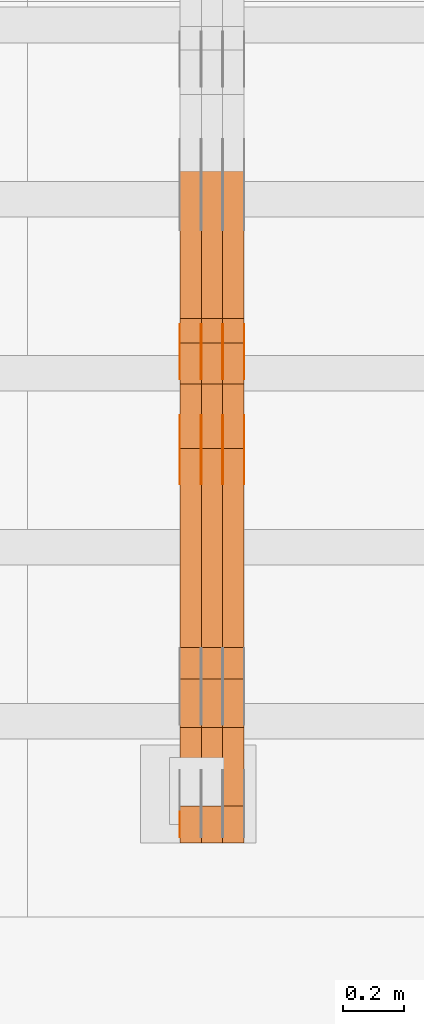
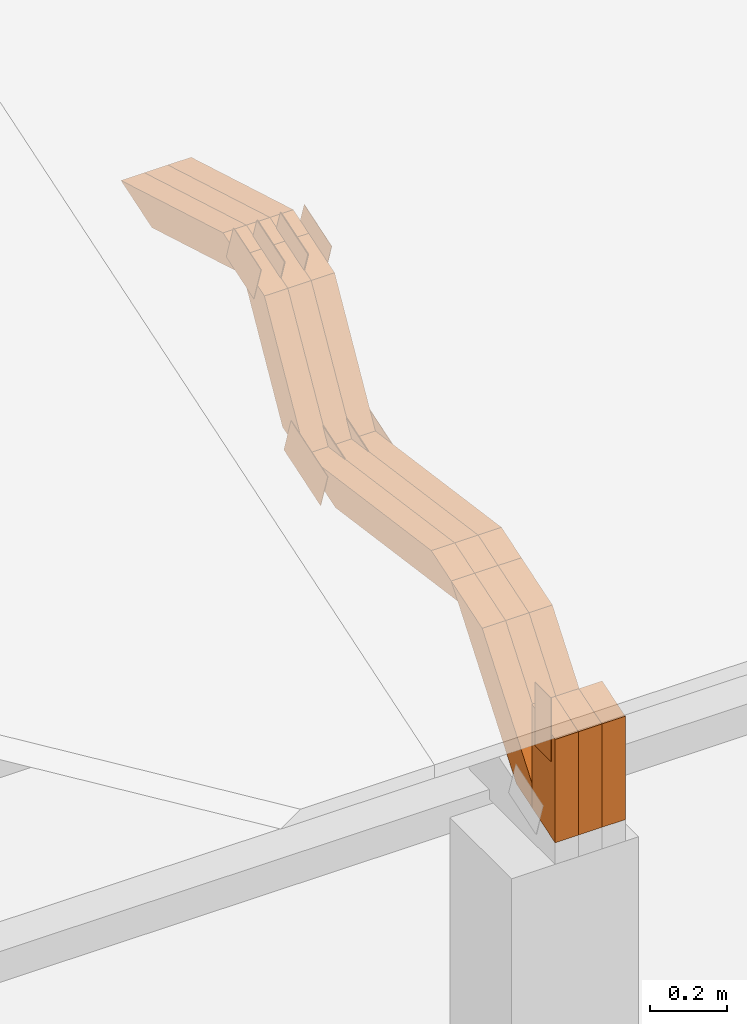
# One storey, part 59 of 385: 28 proxies.
"""IFC2X3 building model written with IfcOpenShell, lengths in millimetres."""

from ifc_helpers import new_model, entity, si_unit, converted_unit, derived_unit, direction, frame, frame_2d, origin, place, context, subcontext, project, spatial, polyline, rectangle, outline, extrude, source, transform, mapped, material, type_object, type_shapes, element, save


model = new_model("IFC2X3")

# Units and contexts
model_context = context("Model", 3, precision=0.01, world=origin(), true_north=direction((6.12303176911189e-17, 1.0)))
body_context = subcontext(model_context, "Body", "Model", "MODEL_VIEW")
ifc_project = project(units=[si_unit("LENGTHUNIT", "METRE", prefix="MILLI"), si_unit("AREAUNIT", "SQUARE_METRE"), si_unit("VOLUMEUNIT", "CUBIC_METRE"), converted_unit("PLANEANGLEUNIT", "DEGREE", entity("IfcRatioMeasure", 0.0174532925199433), si_unit("PLANEANGLEUNIT", "RADIAN"), dimensions=[0, 0, 0, 0, 0, 0, 0]), si_unit("MASSUNIT", "GRAM", prefix="KILO"), derived_unit("MASSDENSITYUNIT", [(si_unit("MASSUNIT", "GRAM", prefix="KILO"), 1), (si_unit("LENGTHUNIT", "METRE"), -3)]), si_unit("TIMEUNIT", "SECOND"), si_unit("FREQUENCYUNIT", "HERTZ"), si_unit("THERMODYNAMICTEMPERATUREUNIT", "DEGREE_CELSIUS"), derived_unit("THERMALTRANSMITTANCEUNIT", [(si_unit("MASSUNIT", "GRAM", prefix="KILO"), 1), (si_unit("THERMODYNAMICTEMPERATUREUNIT", "KELVIN"), -1), (si_unit("TIMEUNIT", "SECOND"), -3)]), derived_unit("VOLUMETRICFLOWRATEUNIT", [(si_unit("LENGTHUNIT", "METRE"), 3), (si_unit("TIMEUNIT", "SECOND"), -1)]), si_unit("ELECTRICCURRENTUNIT", "AMPERE"), si_unit("ELECTRICVOLTAGEUNIT", "VOLT"), si_unit("POWERUNIT", "WATT"), si_unit("FORCEUNIT", "NEWTON", prefix="KILO"), si_unit("ILLUMINANCEUNIT", "LUX"), si_unit("LUMINOUSFLUXUNIT", "LUMEN"), si_unit("LUMINOUSINTENSITYUNIT", "CANDELA"), derived_unit("USERDEFINED", [(si_unit("MASSUNIT", "GRAM", prefix="KILO"), -1), (si_unit("LENGTHUNIT", "METRE"), -2), (si_unit("TIMEUNIT", "SECOND"), 3), (si_unit("LUMINOUSFLUXUNIT", "LUMEN"), 1)]), derived_unit("LINEARVELOCITYUNIT", [(si_unit("LENGTHUNIT", "METRE"), 1), (si_unit("TIMEUNIT", "SECOND"), -1)]), si_unit("PRESSUREUNIT", "PASCAL"), derived_unit("USERDEFINED", [(si_unit("LENGTHUNIT", "METRE"), -2), (si_unit("MASSUNIT", "GRAM", prefix="KILO"), 1), (si_unit("TIMEUNIT", "SECOND"), -2)])], contexts=[model_context])

# Site, building, storey
site_placement = place(None, origin())
site = spatial("IfcSite", under=ifc_project, at=site_placement, CompositionType="ELEMENT")
building_placement = place(site_placement, origin())
building = spatial("IfcBuilding", under=site, at=building_placement, CompositionType="ELEMENT")
storey_placement = place(building_placement, origin())
storey = spatial("IfcBuildingStorey", under=building, at=storey_placement, Name="Default", CompositionType="ELEMENT", Elevation=0.0)

# Proxies
ifc_material_1 = material(Name="IfcSurfaceStyle #201958")
building_element_proxy_type_1 = type_object("IfcBuildingElementProxyType", PredefinedType="NOTDEFINED", material=ifc_material_1)
shared_shape_1 = source(origin(), body_context, "Body", "SweptSolid", [
    extrude(outline(polyline([(-99.9998204243802, -60.000067376167), (99.9998338462265, -60.000067376167), (99.9998204243802, 60.000067376167), (-99.9998338462265, 60.000067376167), (-99.9998204243802, -60.000067376167)])), frame((100.000602015329, 60.0001864986889, 0.0), z_axis=(0.0, 0.0, 1.0), x_axis=(-1.0, 0.0, 0.0)), (0.0, 0.0, 1.0), 1.3),
])
type_shapes(building_element_proxy_type_1, [shared_shape_1])
proxy_1_placement = place(building_placement, frame((15386.3, 4114.85465165112, 513.097031388771), z_axis=(-1.0, 0.0, 0.0), x_axis=(0.0, 0.951056516295124, 0.309016994375039)))
element("IfcBuildingElementProxy", 1, at=proxy_1_placement, inside=storey, type_object=building_element_proxy_type_1, material=ifc_material_1, context=body_context, shape_type="MappedRepresentation", body=[
    mapped(shared_shape_1, transform((0.0, 0.0, 0.0), scale=1.0)),
])
ifc_material_2 = material(Name="IfcSurfaceStyle #201901")
building_element_proxy_type_2 = type_object("IfcBuildingElementProxyType", PredefinedType="NOTDEFINED", material=ifc_material_2)
shared_shape_2 = source(origin(), body_context, "Body", "SweptSolid", [
    extrude(outline(polyline([(-99.9998204243802, -60.000067376167), (99.9998338462265, -60.000067376167), (99.9998204243802, 60.000067376167), (-99.9998338462265, 60.000067376167), (-99.9998204243802, -60.000067376167)])), frame((100.000602015329, 60.0001864986889, 0.0), z_axis=(0.0, 0.0, 1.0), x_axis=(-1.0, 0.0, 0.0)), (0.0, 0.0, 1.0), 1.3),
])
type_shapes(building_element_proxy_type_2, [shared_shape_2])
proxy_2_placement = place(building_placement, frame((15315.0, 4114.85465165112, 513.097031388771), z_axis=(-1.0, 0.0, 0.0), x_axis=(0.0, 0.951056516295124, 0.309016994375039)))
element("IfcBuildingElementProxy", 2, at=proxy_2_placement, inside=storey, type_object=building_element_proxy_type_2, material=ifc_material_2, context=body_context, shape_type="MappedRepresentation", body=[
    mapped(shared_shape_2, transform((0.0, 0.0, 0.0), scale=1.0)),
])
ifc_material_3 = material(Name="IfcSurfaceStyle #201844")
building_element_proxy_type_3 = type_object("IfcBuildingElementProxyType", PredefinedType="NOTDEFINED", material=ifc_material_3)
shared_shape_3 = source(origin(), body_context, "Body", "SweptSolid", [
    extrude(outline(polyline([(-99.9998204243802, -60.000067376167), (99.9998338462265, -60.000067376167), (99.9998204243802, 60.000067376167), (-99.9998338462265, 60.000067376167), (-99.9998204243802, -60.000067376167)])), frame((100.000602015329, 60.0001864986889, 0.0), z_axis=(0.0, 0.0, 1.0), x_axis=(-1.0, 0.0, 0.0)), (0.0, 0.0, 1.0), 1.3),
])
type_shapes(building_element_proxy_type_3, [shared_shape_3])
proxy_3_placement = place(building_placement, frame((15316.3, 4114.85465165112, 513.097031388771), z_axis=(-1.0, 0.0, 0.0), x_axis=(0.0, 0.951056516295124, 0.309016994375039)))
element("IfcBuildingElementProxy", 3, at=proxy_3_placement, inside=storey, type_object=building_element_proxy_type_3, material=ifc_material_3, context=body_context, shape_type="MappedRepresentation", body=[
    mapped(shared_shape_3, transform((0.0, 0.0, 0.0), scale=1.0)),
])
ifc_material_4 = material(Name="IfcSurfaceStyle #201787")
building_element_proxy_type_4 = type_object("IfcBuildingElementProxyType", PredefinedType="NOTDEFINED", material=ifc_material_4)
shared_shape_4 = source(origin(), body_context, "Body", "SweptSolid", [
    extrude(outline(polyline([(-99.9998204243802, -60.000067376167), (99.9998338462265, -60.000067376167), (99.9998204243802, 60.000067376167), (-99.9998338462265, 60.000067376167), (-99.9998204243802, -60.000067376167)])), frame((100.000602015329, 60.0001864986889, 0.0), z_axis=(0.0, 0.0, 1.0), x_axis=(-1.0, 0.0, 0.0)), (0.0, 0.0, 1.0), 1.29999999999998),
])
type_shapes(building_element_proxy_type_4, [shared_shape_4])
proxy_4_placement = place(building_placement, frame((15245.0, 4114.85465165112, 513.097031388771), z_axis=(-1.0, 0.0, 0.0), x_axis=(0.0, 0.951056516295124, 0.309016994375039)))
element("IfcBuildingElementProxy", 4, at=proxy_4_placement, inside=storey, type_object=building_element_proxy_type_4, material=ifc_material_4, context=body_context, shape_type="MappedRepresentation", body=[
    mapped(shared_shape_4, transform((0.0, 0.0, 0.0), scale=1.0)),
])
ifc_material_5 = material(Name="IfcSurfaceStyle #201730")
building_element_proxy_type_5 = type_object("IfcBuildingElementProxyType", PredefinedType="NOTDEFINED", material=ifc_material_5)
shared_shape_5 = source(origin(), body_context, "Body", "SweptSolid", [
    extrude(outline(polyline([(-99.9998204243802, -60.000067376167), (99.9998338462265, -60.000067376167), (99.9998204243802, 60.000067376167), (-99.9998338462265, 60.000067376167), (-99.9998204243802, -60.000067376167)])), frame((100.000602015329, 60.0001864986889, 0.0), z_axis=(0.0, 0.0, 1.0), x_axis=(-1.0, 0.0, 0.0)), (0.0, 0.0, 1.0), 1.29999999999998),
])
type_shapes(building_element_proxy_type_5, [shared_shape_5])
proxy_5_placement = place(building_placement, frame((15246.3, 4114.85465165112, 513.097031388771), z_axis=(-1.0, 0.0, 0.0), x_axis=(0.0, 0.951056516295124, 0.309016994375039)))
element("IfcBuildingElementProxy", 5, at=proxy_5_placement, inside=storey, type_object=building_element_proxy_type_5, material=ifc_material_5, context=body_context, shape_type="MappedRepresentation", body=[
    mapped(shared_shape_5, transform((0.0, 0.0, 0.0), scale=1.0)),
])
ifc_material_6 = material(Name="IfcSurfaceStyle #201673")
building_element_proxy_type_6 = type_object("IfcBuildingElementProxyType", PredefinedType="NOTDEFINED", material=ifc_material_6)
shared_shape_6 = source(origin(), body_context, "Body", "SweptSolid", [
    extrude(outline(polyline([(-99.9998204243802, -60.000067376167), (99.9998338462265, -60.000067376167), (99.9998204243802, 60.000067376167), (-99.9998338462265, 60.000067376167), (-99.9998204243802, -60.000067376167)])), frame((100.000602015329, 60.0001864986889, 0.0), z_axis=(0.0, 0.0, 1.0), x_axis=(-1.0, 0.0, 0.0)), (0.0, 0.0, 1.0), 1.29999999999999),
])
type_shapes(building_element_proxy_type_6, [shared_shape_6])
proxy_6_placement = place(building_placement, frame((15175.0, 4114.85465165112, 513.097031388771), z_axis=(-1.0, 0.0, 0.0), x_axis=(0.0, 0.951056516295124, 0.309016994375039)))
element("IfcBuildingElementProxy", 6, at=proxy_6_placement, inside=storey, type_object=building_element_proxy_type_6, material=ifc_material_6, context=body_context, shape_type="MappedRepresentation", body=[
    mapped(shared_shape_6, transform((0.0, 0.0, 0.0), scale=1.0)),
])
ifc_material_7 = material(Name="IfcSurfaceStyle #194776")
building_element_proxy_type_7 = type_object("IfcBuildingElementProxyType", PredefinedType="NOTDEFINED", material=ifc_material_7)
shared_shape_7 = source(origin(), body_context, "Body", "SweptSolid", [
    extrude(outline(polyline([(-74.999865998172, -60.0000306612919), (74.999869989555, -60.0000306612919), (74.999865998172, 60.0000306612919), (-74.999869989555, 60.0000306612919), (-74.999865998172, -60.0000306612919)])), frame((75.0006726017528, 60.0001996460842, 0.0), z_axis=(0.0, 0.0, 1.0), x_axis=(-1.0, 0.0, 0.0)), (0.0, 0.0, 1.0), 1.3),
])
type_shapes(building_element_proxy_type_7, [shared_shape_7])
proxy_7_placement = place(building_placement, frame((15386.3, 4460.38978242656, 957.314497110567), z_axis=(-1.0, 0.0, 0.0), x_axis=(0.0, 0.951056516295154, 0.309016994374948)))
element("IfcBuildingElementProxy", 7, at=proxy_7_placement, inside=storey, type_object=building_element_proxy_type_7, material=ifc_material_7, context=body_context, shape_type="MappedRepresentation", body=[
    mapped(shared_shape_7, transform((0.0, 0.0, 0.0), scale=1.0)),
])
ifc_material_8 = material(Name="IfcSurfaceStyle #194719")
building_element_proxy_type_8 = type_object("IfcBuildingElementProxyType", PredefinedType="NOTDEFINED", material=ifc_material_8)
shared_shape_8 = source(origin(), body_context, "Body", "SweptSolid", [
    extrude(outline(polyline([(-74.999865998172, -60.0000306612919), (74.999869989555, -60.0000306612919), (74.999865998172, 60.0000306612919), (-74.999869989555, 60.0000306612919), (-74.999865998172, -60.0000306612919)])), frame((75.0006726017528, 60.0001996460842, 0.0), z_axis=(0.0, 0.0, 1.0), x_axis=(-1.0, 0.0, 0.0)), (0.0, 0.0, 1.0), 1.3),
])
type_shapes(building_element_proxy_type_8, [shared_shape_8])
proxy_8_placement = place(building_placement, frame((15315.0, 4460.38978242656, 957.314497110567), z_axis=(-1.0, 0.0, 0.0), x_axis=(0.0, 0.951056516295154, 0.309016994374948)))
element("IfcBuildingElementProxy", 8, at=proxy_8_placement, inside=storey, type_object=building_element_proxy_type_8, material=ifc_material_8, context=body_context, shape_type="MappedRepresentation", body=[
    mapped(shared_shape_8, transform((0.0, 0.0, 0.0), scale=1.0)),
])
ifc_material_9 = material(Name="IfcSurfaceStyle #194662")
building_element_proxy_type_9 = type_object("IfcBuildingElementProxyType", PredefinedType="NOTDEFINED", material=ifc_material_9)
shared_shape_9 = source(origin(), body_context, "Body", "SweptSolid", [
    extrude(outline(polyline([(-74.999865998172, -60.0000306612919), (74.999869989555, -60.0000306612919), (74.999865998172, 60.0000306612919), (-74.999869989555, 60.0000306612919), (-74.999865998172, -60.0000306612919)])), frame((75.0006726017528, 60.0001996460842, 0.0), z_axis=(0.0, 0.0, 1.0), x_axis=(-1.0, 0.0, 0.0)), (0.0, 0.0, 1.0), 1.3),
])
type_shapes(building_element_proxy_type_9, [shared_shape_9])
proxy_9_placement = place(building_placement, frame((15316.3, 4460.38978242656, 957.314497110567), z_axis=(-1.0, 0.0, 0.0), x_axis=(0.0, 0.951056516295154, 0.309016994374948)))
element("IfcBuildingElementProxy", 9, at=proxy_9_placement, inside=storey, type_object=building_element_proxy_type_9, material=ifc_material_9, context=body_context, shape_type="MappedRepresentation", body=[
    mapped(shared_shape_9, transform((0.0, 0.0, 0.0), scale=1.0)),
])
ifc_material_10 = material(Name="IfcSurfaceStyle #194605")
building_element_proxy_type_10 = type_object("IfcBuildingElementProxyType", PredefinedType="NOTDEFINED", material=ifc_material_10)
shared_shape_10 = source(origin(), body_context, "Body", "SweptSolid", [
    extrude(outline(polyline([(-74.999865998172, -60.0000306612919), (74.999869989555, -60.0000306612919), (74.999865998172, 60.0000306612919), (-74.999869989555, 60.0000306612919), (-74.999865998172, -60.0000306612919)])), frame((75.0006726017528, 60.0001996460842, 0.0), z_axis=(0.0, 0.0, 1.0), x_axis=(-1.0, 0.0, 0.0)), (0.0, 0.0, 1.0), 1.29999999999999),
])
type_shapes(building_element_proxy_type_10, [shared_shape_10])
proxy_10_placement = place(building_placement, frame((15245.0, 4460.38978242656, 957.314497110567), z_axis=(-1.0, 0.0, 0.0), x_axis=(0.0, 0.951056516295154, 0.309016994374948)))
element("IfcBuildingElementProxy", 10, at=proxy_10_placement, inside=storey, type_object=building_element_proxy_type_10, material=ifc_material_10, context=body_context, shape_type="MappedRepresentation", body=[
    mapped(shared_shape_10, transform((0.0, 0.0, 0.0), scale=1.0)),
])
ifc_material_11 = material(Name="IfcSurfaceStyle #194548")
building_element_proxy_type_11 = type_object("IfcBuildingElementProxyType", PredefinedType="NOTDEFINED", material=ifc_material_11)
shared_shape_11 = source(origin(), body_context, "Body", "SweptSolid", [
    extrude(outline(polyline([(-74.999865998172, -60.0000306612919), (74.999869989555, -60.0000306612919), (74.999865998172, 60.0000306612919), (-74.999869989555, 60.0000306612919), (-74.999865998172, -60.0000306612919)])), frame((75.0006726017528, 60.0001996460842, 0.0), z_axis=(0.0, 0.0, 1.0), x_axis=(-1.0, 0.0, 0.0)), (0.0, 0.0, 1.0), 1.29999999999999),
])
type_shapes(building_element_proxy_type_11, [shared_shape_11])
proxy_11_placement = place(building_placement, frame((15246.3, 4460.38978242656, 957.314497110567), z_axis=(-1.0, 0.0, 0.0), x_axis=(0.0, 0.951056516295154, 0.309016994374948)))
element("IfcBuildingElementProxy", 11, at=proxy_11_placement, inside=storey, type_object=building_element_proxy_type_11, material=ifc_material_11, context=body_context, shape_type="MappedRepresentation", body=[
    mapped(shared_shape_11, transform((0.0, 0.0, 0.0), scale=1.0)),
])
ifc_material_12 = material(Name="IfcSurfaceStyle #194491")
building_element_proxy_type_12 = type_object("IfcBuildingElementProxyType", PredefinedType="NOTDEFINED", material=ifc_material_12)
shared_shape_12 = source(origin(), body_context, "Body", "SweptSolid", [
    extrude(outline(polyline([(-74.999865998172, -60.0000306612919), (74.999869989555, -60.0000306612919), (74.999865998172, 60.0000306612919), (-74.999869989555, 60.0000306612919), (-74.999865998172, -60.0000306612919)])), frame((75.0006726017528, 60.0001996460842, 0.0), z_axis=(0.0, 0.0, 1.0), x_axis=(-1.0, 0.0, 0.0)), (0.0, 0.0, 1.0), 1.29999999999999),
])
type_shapes(building_element_proxy_type_12, [shared_shape_12])
proxy_12_placement = place(building_placement, frame((15175.0, 4460.38978242656, 957.314497110567), z_axis=(-1.0, 0.0, 0.0), x_axis=(0.0, 0.951056516295154, 0.309016994374948)))
element("IfcBuildingElementProxy", 12, at=proxy_12_placement, inside=storey, type_object=building_element_proxy_type_12, material=ifc_material_12, context=body_context, shape_type="MappedRepresentation", body=[
    mapped(shared_shape_12, transform((0.0, 0.0, 0.0), scale=1.0)),
])
ifc_material_13 = material(Name="IfcSurfaceStyle #192439")
building_element_proxy_type_13 = type_object("IfcBuildingElementProxyType", PredefinedType="NOTDEFINED", material=ifc_material_13)
shared_shape_13 = source(origin(), body_context, "Body", "SweptSolid", [
    extrude(rectangle(XDim=199.999969482422, YDim=84.0, at=frame_2d((1.4210854715202e-14, 0.0), x_axis=(1.0, 0.0))), frame((100.000010815955, 42.0, 0.0), z_axis=(0.0, 0.0, 1.0), x_axis=(-1.0, 0.0, 0.0)), (0.0, 0.0, 1.0), 1.29999999999999),
])
type_shapes(building_element_proxy_type_13, [shared_shape_13])
proxy_13_placement = place(building_placement, frame((15175.0, 3042.0, 514.460048047401), z_axis=(-1.0, 0.0, 0.0), x_axis=(0.0, 0.0, -1.0)))
element("IfcBuildingElementProxy", 13, at=proxy_13_placement, inside=storey, type_object=building_element_proxy_type_13, material=ifc_material_13, context=body_context, shape_type="MappedRepresentation", body=[
    mapped(shared_shape_13, transform((0.0, 0.0, 0.0), scale=1.0)),
])
ifc_material_14 = material(Name="IfcSurfaceStyle #182248")
building_element_proxy_type_14 = type_object("IfcBuildingElementProxyType", Name="T1-W12 182246", PredefinedType="NOTDEFINED", material=ifc_material_14)
shared_shape_14 = source(origin(), body_context, "Body", "SweptSolid", [
    extrude(outline(polyline([(-249.405625983165, -47.5001691155616), (243.345753908996, -47.5001691155616), (232.115534842595, 2.39993474701938e-05), (162.527010966644, 47.5001571158879), (-388.58267373507, 47.5001571158879), (-249.405625983165, -47.5001691155616)])), frame((243.345867653852, 47.5001571158879, 0.0), z_axis=(0.0, 0.0, 1.0), x_axis=(-1.0, 0.0, 0.0)), (0.0, 0.0, 1.0), 70.0),
])
type_shapes(building_element_proxy_type_14, [shared_shape_14])
proxy_14_placement = place(building_placement, frame((15385.0, 4581.32698473631, 976.172276753357), z_axis=(-1.0, 0.0, 0.0), x_axis=(0.0, 0.959722067881787, -0.280951156645966)))
element("IfcBuildingElementProxy", 14, at=proxy_14_placement, inside=storey, type_object=building_element_proxy_type_14, material=ifc_material_14, Name="T1-W12", context=body_context, shape_type="MappedRepresentation", body=[
    mapped(shared_shape_14, transform((0.0, 0.0, 0.0), scale=1.0)),
])
ifc_material_15 = material(Name="IfcSurfaceStyle #182182")
building_element_proxy_type_15 = type_object("IfcBuildingElementProxyType", Name="T1-W12 182180", PredefinedType="NOTDEFINED", material=ifc_material_15)
shared_shape_15 = source(origin(), body_context, "Body", "SweptSolid", [
    extrude(outline(polyline([(-249.405625983165, -47.5001691155616), (243.345753908996, -47.5001691155616), (232.115534842595, 2.39993474701938e-05), (162.527010966644, 47.5001571158879), (-388.58267373507, 47.5001571158879), (-249.405625983165, -47.5001691155616)])), frame((243.345867653852, 47.5001571158879, 0.0), z_axis=(0.0, 0.0, 1.0), x_axis=(-1.0, 0.0, 0.0)), (0.0, 0.0, 1.0), 70.0),
])
type_shapes(building_element_proxy_type_15, [shared_shape_15])
proxy_15_placement = place(building_placement, frame((15315.0, 4581.32698473631, 976.172276753357), z_axis=(-1.0, 0.0, 0.0), x_axis=(0.0, 0.959722067881787, -0.280951156645966)))
element("IfcBuildingElementProxy", 15, at=proxy_15_placement, inside=storey, type_object=building_element_proxy_type_15, material=ifc_material_15, Name="T1-W12", context=body_context, shape_type="MappedRepresentation", body=[
    mapped(shared_shape_15, transform((0.0, 0.0, 0.0), scale=1.0)),
])
ifc_material_16 = material(Name="IfcSurfaceStyle #182116")
building_element_proxy_type_16 = type_object("IfcBuildingElementProxyType", Name="T1-W12 182114", PredefinedType="NOTDEFINED", material=ifc_material_16)
shared_shape_16 = source(origin(), body_context, "Body", "SweptSolid", [
    extrude(outline(polyline([(-249.405625983165, -47.5001691155616), (243.345753908996, -47.5001691155616), (232.115534842595, 2.39993474701938e-05), (162.527010966644, 47.5001571158879), (-388.58267373507, 47.5001571158879), (-249.405625983165, -47.5001691155616)])), frame((243.345867653852, 47.5001571158879, 0.0), z_axis=(0.0, 0.0, 1.0), x_axis=(-1.0, 0.0, 0.0)), (0.0, 0.0, 1.0), 70.0),
])
type_shapes(building_element_proxy_type_16, [shared_shape_16])
proxy_16_placement = place(building_placement, frame((15245.0, 4581.32698473631, 976.172276753357), z_axis=(-1.0, 0.0, 0.0), x_axis=(0.0, 0.959722067881787, -0.280951156645966)))
element("IfcBuildingElementProxy", 16, at=proxy_16_placement, inside=storey, type_object=building_element_proxy_type_16, material=ifc_material_16, Name="T1-W12", context=body_context, shape_type="MappedRepresentation", body=[
    mapped(shared_shape_16, transform((0.0, 0.0, 0.0), scale=1.0)),
])
ifc_material_17 = material(Name="IfcSurfaceStyle #181852")
building_element_proxy_type_17 = type_object("IfcBuildingElementProxyType", Name="T1-W27 181850", PredefinedType="NOTDEFINED", material=ifc_material_17)
shared_shape_17 = source(origin(), body_context, "Body", "SweptSolid", [
    extrude(outline(polyline([(-321.979763159708, -47.49993999164), (138.960018341432, -47.49993999164), (191.013775341887, -0.000473170132329126), (209.87827169492, 47.5001765767061), (-217.872302218531, 47.5001765767062), (-321.979763159708, -47.49993999164)])), frame((209.87827169492, 47.5001765767061, 0.0), z_axis=(0.0, 0.0, 1.0), x_axis=(-1.0, 0.0, 0.0)), (0.0, 0.0, 1.0), 70.0),
])
type_shapes(building_element_proxy_type_17, [shared_shape_17])
proxy_17_placement = place(building_placement, frame((15385.0, 4233.3125, 512.021728515625), z_axis=(-1.0, 0.0, 0.0), x_axis=(0.0, 0.494231057369727, 0.869330582650352)))
element("IfcBuildingElementProxy", 17, at=proxy_17_placement, inside=storey, type_object=building_element_proxy_type_17, material=ifc_material_17, Name="T1-W27", context=body_context, shape_type="MappedRepresentation", body=[
    mapped(shared_shape_17, transform((0.0, 0.0, 0.0), scale=1.0)),
])
ifc_material_18 = material(Name="IfcSurfaceStyle #181786")
building_element_proxy_type_18 = type_object("IfcBuildingElementProxyType", Name="T1-W27 181784", PredefinedType="NOTDEFINED", material=ifc_material_18)
shared_shape_18 = source(origin(), body_context, "Body", "SweptSolid", [
    extrude(outline(polyline([(-321.979763159708, -47.49993999164), (138.960018341432, -47.49993999164), (191.013775341887, -0.000473170132329126), (209.87827169492, 47.5001765767061), (-217.872302218531, 47.5001765767062), (-321.979763159708, -47.49993999164)])), frame((209.87827169492, 47.5001765767061, 0.0), z_axis=(0.0, 0.0, 1.0), x_axis=(-1.0, 0.0, 0.0)), (0.0, 0.0, 1.0), 70.0),
])
type_shapes(building_element_proxy_type_18, [shared_shape_18])
proxy_18_placement = place(building_placement, frame((15315.0, 4233.3125, 512.021728515625), z_axis=(-1.0, 0.0, 0.0), x_axis=(0.0, 0.494231057369727, 0.869330582650352)))
element("IfcBuildingElementProxy", 18, at=proxy_18_placement, inside=storey, type_object=building_element_proxy_type_18, material=ifc_material_18, Name="T1-W27", context=body_context, shape_type="MappedRepresentation", body=[
    mapped(shared_shape_18, transform((0.0, 0.0, 0.0), scale=1.0)),
])
ifc_material_19 = material(Name="IfcSurfaceStyle #181720")
building_element_proxy_type_19 = type_object("IfcBuildingElementProxyType", Name="T1-W27 181718", PredefinedType="NOTDEFINED", material=ifc_material_19)
shared_shape_19 = source(origin(), body_context, "Body", "SweptSolid", [
    extrude(outline(polyline([(-321.979763159708, -47.49993999164), (138.960018341432, -47.49993999164), (191.013775341887, -0.000473170132329126), (209.87827169492, 47.5001765767061), (-217.872302218531, 47.5001765767062), (-321.979763159708, -47.49993999164)])), frame((209.87827169492, 47.5001765767061, 0.0), z_axis=(0.0, 0.0, 1.0), x_axis=(-1.0, 0.0, 0.0)), (0.0, 0.0, 1.0), 70.0),
])
type_shapes(building_element_proxy_type_19, [shared_shape_19])
proxy_19_placement = place(building_placement, frame((15245.0, 4233.3125, 512.021728515625), z_axis=(-1.0, 0.0, 0.0), x_axis=(0.0, 0.494231057369727, 0.869330582650352)))
element("IfcBuildingElementProxy", 19, at=proxy_19_placement, inside=storey, type_object=building_element_proxy_type_19, material=ifc_material_19, Name="T1-W27", context=body_context, shape_type="MappedRepresentation", body=[
    mapped(shared_shape_19, transform((0.0, 0.0, 0.0), scale=1.0)),
])
ifc_material_20 = material(Name="IfcSurfaceStyle #181456")
building_element_proxy_type_20 = type_object("IfcBuildingElementProxyType", Name="T1-W3 181454", PredefinedType="NOTDEFINED", material=ifc_material_20)
shared_shape_20 = source(origin(), body_context, "Body", "SweptSolid", [
    extrude(outline(polyline([(-314.232579911788, -47.5000200125938), (325.164873061766, -47.5000200125938), (297.999869081008, 6.48085173424295e-05), (200.434027234171, 47.4999876083351), (-509.366189465157, 47.4999876083352), (-314.232579911788, -47.5000200125938)])), frame((325.164873061766, 47.5001564752191, 0.0), z_axis=(0.0, 0.0, 1.0), x_axis=(-1.0, 0.0, 0.0)), (0.0, 0.0, 1.0), 70.0),
])
type_shapes(building_element_proxy_type_20, [shared_shape_20])
proxy_20_placement = place(building_placement, frame((15385.0, 3457.43747924875, 620.49890325051), z_axis=(-1.0, 0.0, 0.0), x_axis=(0.0, 0.990367219823621, -0.138465771578512)))
element("IfcBuildingElementProxy", 20, at=proxy_20_placement, inside=storey, type_object=building_element_proxy_type_20, material=ifc_material_20, Name="T1-W3", context=body_context, shape_type="MappedRepresentation", body=[
    mapped(shared_shape_20, transform((0.0, 0.0, 0.0), scale=1.0)),
])
ifc_material_21 = material(Name="IfcSurfaceStyle #181390")
building_element_proxy_type_21 = type_object("IfcBuildingElementProxyType", Name="T1-W3 181388", PredefinedType="NOTDEFINED", material=ifc_material_21)
shared_shape_21 = source(origin(), body_context, "Body", "SweptSolid", [
    extrude(outline(polyline([(-314.232579911788, -47.5000200125938), (325.164873061766, -47.5000200125938), (297.999869081008, 6.48085173424295e-05), (200.434027234171, 47.4999876083351), (-509.366189465157, 47.4999876083352), (-314.232579911788, -47.5000200125938)])), frame((325.164873061766, 47.5001564752191, 0.0), z_axis=(0.0, 0.0, 1.0), x_axis=(-1.0, 0.0, 0.0)), (0.0, 0.0, 1.0), 70.0),
])
type_shapes(building_element_proxy_type_21, [shared_shape_21])
proxy_21_placement = place(building_placement, frame((15315.0, 3457.43747924875, 620.49890325051), z_axis=(-1.0, 0.0, 0.0), x_axis=(0.0, 0.990367219823621, -0.138465771578512)))
element("IfcBuildingElementProxy", 21, at=proxy_21_placement, inside=storey, type_object=building_element_proxy_type_21, material=ifc_material_21, Name="T1-W3", context=body_context, shape_type="MappedRepresentation", body=[
    mapped(shared_shape_21, transform((0.0, 0.0, 0.0), scale=1.0)),
])
ifc_material_22 = material(Name="IfcSurfaceStyle #181324")
building_element_proxy_type_22 = type_object("IfcBuildingElementProxyType", Name="T1-W3 181322", PredefinedType="NOTDEFINED", material=ifc_material_22)
shared_shape_22 = source(origin(), body_context, "Body", "SweptSolid", [
    extrude(outline(polyline([(-314.232579911788, -47.5000200125938), (325.164873061766, -47.5000200125938), (297.999869081008, 6.48085173424295e-05), (200.434027234171, 47.4999876083351), (-509.366189465157, 47.4999876083352), (-314.232579911788, -47.5000200125938)])), frame((325.164873061766, 47.5001564752191, 0.0), z_axis=(0.0, 0.0, 1.0), x_axis=(-1.0, 0.0, 0.0)), (0.0, 0.0, 1.0), 70.0),
])
type_shapes(building_element_proxy_type_22, [shared_shape_22])
proxy_22_placement = place(building_placement, frame((15245.0, 3457.43747924875, 620.49890325051), z_axis=(-1.0, 0.0, 0.0), x_axis=(0.0, 0.990367219823621, -0.138465771578512)))
element("IfcBuildingElementProxy", 22, at=proxy_22_placement, inside=storey, type_object=building_element_proxy_type_22, material=ifc_material_22, Name="T1-W3", context=body_context, shape_type="MappedRepresentation", body=[
    mapped(shared_shape_22, transform((0.0, 0.0, 0.0), scale=1.0)),
])
ifc_material_23 = material(Name="IfcSurfaceStyle #181060")
building_element_proxy_type_23 = type_object("IfcBuildingElementProxyType", Name="T1-W14 181058", PredefinedType="NOTDEFINED", material=ifc_material_23)
shared_shape_23 = source(origin(), body_context, "Body", "SweptSolid", [
    extrude(outline(polyline([(-374.484689776928, -47.499919737532), (177.199556189275, -47.499919737532), (246.893257937645, -5.36774925340877e-05), (185.487930694801, 47.4999465762783), (-235.096055044793, 47.4999465762784), (-374.484689776928, -47.499919737532)])), frame((246.893257937645, 47.5000959779252, 0.0), z_axis=(0.0, 0.0, 1.0), x_axis=(-1.0, 0.0, 0.0)), (0.0, 0.0, 1.0), 70.0),
])
type_shapes(building_element_proxy_type_23, [shared_shape_23])
proxy_23_placement = place(building_placement, frame((15385.0, 3022.42877773024, 136.329406512195), z_axis=(-1.0, 0.0, 0.0), x_axis=(0.0, 0.611854146609475, 0.790970608352037)))
element("IfcBuildingElementProxy", 23, at=proxy_23_placement, inside=storey, type_object=building_element_proxy_type_23, material=ifc_material_23, Name="T1-W14", context=body_context, shape_type="MappedRepresentation", body=[
    mapped(shared_shape_23, transform((0.0, 0.0, 0.0), scale=1.0)),
])
ifc_material_24 = material(Name="IfcSurfaceStyle #180994")
building_element_proxy_type_24 = type_object("IfcBuildingElementProxyType", Name="T1-W14 180992", PredefinedType="NOTDEFINED", material=ifc_material_24)
shared_shape_24 = source(origin(), body_context, "Body", "SweptSolid", [
    extrude(outline(polyline([(-374.484689776928, -47.499919737532), (177.199556189275, -47.499919737532), (246.893257937645, -5.36774925340877e-05), (185.487930694801, 47.4999465762783), (-235.096055044793, 47.4999465762784), (-374.484689776928, -47.499919737532)])), frame((246.893257937645, 47.5000959779252, 0.0), z_axis=(0.0, 0.0, 1.0), x_axis=(-1.0, 0.0, 0.0)), (0.0, 0.0, 1.0), 70.0),
])
type_shapes(building_element_proxy_type_24, [shared_shape_24])
proxy_24_placement = place(building_placement, frame((15315.0, 3022.42877773024, 136.329406512195), z_axis=(-1.0, 0.0, 0.0), x_axis=(0.0, 0.611854146609475, 0.790970608352037)))
element("IfcBuildingElementProxy", 24, at=proxy_24_placement, inside=storey, type_object=building_element_proxy_type_24, material=ifc_material_24, Name="T1-W14", context=body_context, shape_type="MappedRepresentation", body=[
    mapped(shared_shape_24, transform((0.0, 0.0, 0.0), scale=1.0)),
])
ifc_material_25 = material(Name="IfcSurfaceStyle #180928")
building_element_proxy_type_25 = type_object("IfcBuildingElementProxyType", Name="T1-W14 180926", PredefinedType="NOTDEFINED", material=ifc_material_25)
shared_shape_25 = source(origin(), body_context, "Body", "SweptSolid", [
    extrude(outline(polyline([(-374.484689776928, -47.499919737532), (177.199556189275, -47.499919737532), (246.893257937645, -5.36774925340877e-05), (185.487930694801, 47.4999465762783), (-235.096055044793, 47.4999465762784), (-374.484689776928, -47.499919737532)])), frame((246.893257937645, 47.5000959779252, 0.0), z_axis=(0.0, 0.0, 1.0), x_axis=(-1.0, 0.0, 0.0)), (0.0, 0.0, 1.0), 70.0),
])
type_shapes(building_element_proxy_type_25, [shared_shape_25])
proxy_25_placement = place(building_placement, frame((15245.0, 3022.42877773024, 136.329406512195), z_axis=(-1.0, 0.0, 0.0), x_axis=(0.0, 0.611854146609475, 0.790970608352037)))
element("IfcBuildingElementProxy", 25, at=proxy_25_placement, inside=storey, type_object=building_element_proxy_type_25, material=ifc_material_25, Name="T1-W14", context=body_context, shape_type="MappedRepresentation", body=[
    mapped(shared_shape_25, transform((0.0, 0.0, 0.0), scale=1.0)),
])
ifc_material_26 = material(Name="IfcSurfaceStyle #180862")
building_element_proxy_type_26 = type_object("IfcBuildingElementProxyType", Name="T1-E3 180860", PredefinedType="NOTDEFINED", material=ifc_material_26)
shared_shape_26 = source(origin(), body_context, "Body", "SweptSolid", [
    extrude(outline(polyline([(-182.839673995971, -60.0), (143.849313735962, -60.0), (182.839677810669, 60.0), (-143.84931755066, 60.0), (-182.839673995971, -60.0)])), frame((182.839677810669, 60.0, 0.0), z_axis=(0.0, 0.0, 1.0), x_axis=(-1.0, 0.0, 0.0)), (0.0, 0.0, 1.0), 70.0),
])
type_shapes(building_element_proxy_type_26, [shared_shape_26])
proxy_26_placement = place(building_placement, frame((15385.0, 2940.0, 68.27587890625), z_axis=(-1.0, 0.0, 0.0), x_axis=(0.0, 0.0, 1.0)))
element("IfcBuildingElementProxy", 26, at=proxy_26_placement, inside=storey, type_object=building_element_proxy_type_26, material=ifc_material_26, Name="T1-E3", context=body_context, shape_type="MappedRepresentation", body=[
    mapped(shared_shape_26, transform((0.0, 0.0, 0.0), scale=1.0)),
])
ifc_material_27 = material(Name="IfcSurfaceStyle #180805")
building_element_proxy_type_27 = type_object("IfcBuildingElementProxyType", Name="T1-E3 180803", PredefinedType="NOTDEFINED", material=ifc_material_27)
shared_shape_27 = source(origin(), body_context, "Body", "SweptSolid", [
    extrude(outline(polyline([(-182.839673995971, -60.0), (143.849313735962, -60.0), (182.839677810669, 60.0), (-143.84931755066, 60.0), (-182.839673995971, -60.0)])), frame((182.839677810669, 60.0, 0.0), z_axis=(0.0, 0.0, 1.0), x_axis=(-1.0, 0.0, 0.0)), (0.0, 0.0, 1.0), 70.0),
])
type_shapes(building_element_proxy_type_27, [shared_shape_27])
proxy_27_placement = place(building_placement, frame((15315.0, 2940.0, 68.27587890625), z_axis=(-1.0, 0.0, 0.0), x_axis=(0.0, 0.0, 1.0)))
element("IfcBuildingElementProxy", 27, at=proxy_27_placement, inside=storey, type_object=building_element_proxy_type_27, material=ifc_material_27, Name="T1-E3", context=body_context, shape_type="MappedRepresentation", body=[
    mapped(shared_shape_27, transform((0.0, 0.0, 0.0), scale=1.0)),
])
ifc_material_28 = material(Name="IfcSurfaceStyle #180748")
building_element_proxy_type_28 = type_object("IfcBuildingElementProxyType", Name="T1-E3 180746", PredefinedType="NOTDEFINED", material=ifc_material_28)
shared_shape_28 = source(origin(), body_context, "Body", "SweptSolid", [
    extrude(outline(polyline([(-182.839673995971, -60.0), (143.849313735962, -60.0), (182.839677810669, 60.0), (-143.84931755066, 60.0), (-182.839673995971, -60.0)])), frame((182.839677810669, 60.0, 0.0), z_axis=(0.0, 0.0, 1.0), x_axis=(-1.0, 0.0, 0.0)), (0.0, 0.0, 1.0), 70.0),
])
type_shapes(building_element_proxy_type_28, [shared_shape_28])
proxy_28_placement = place(building_placement, frame((15245.0, 2940.0, 68.27587890625), z_axis=(-1.0, 0.0, 0.0), x_axis=(0.0, 0.0, 1.0)))
element("IfcBuildingElementProxy", 28, at=proxy_28_placement, inside=storey, type_object=building_element_proxy_type_28, material=ifc_material_28, Name="T1-E3", context=body_context, shape_type="MappedRepresentation", body=[
    mapped(shared_shape_28, transform((0.0, 0.0, 0.0), scale=1.0)),
])

save(model, "model.ifc")
